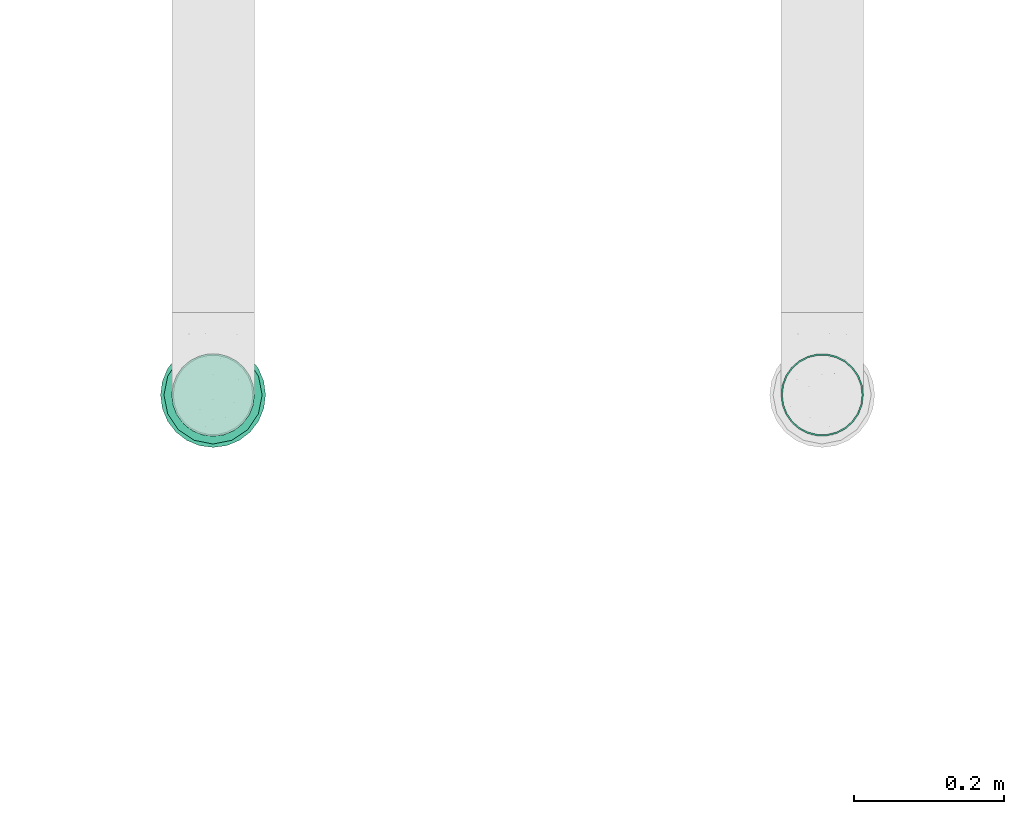
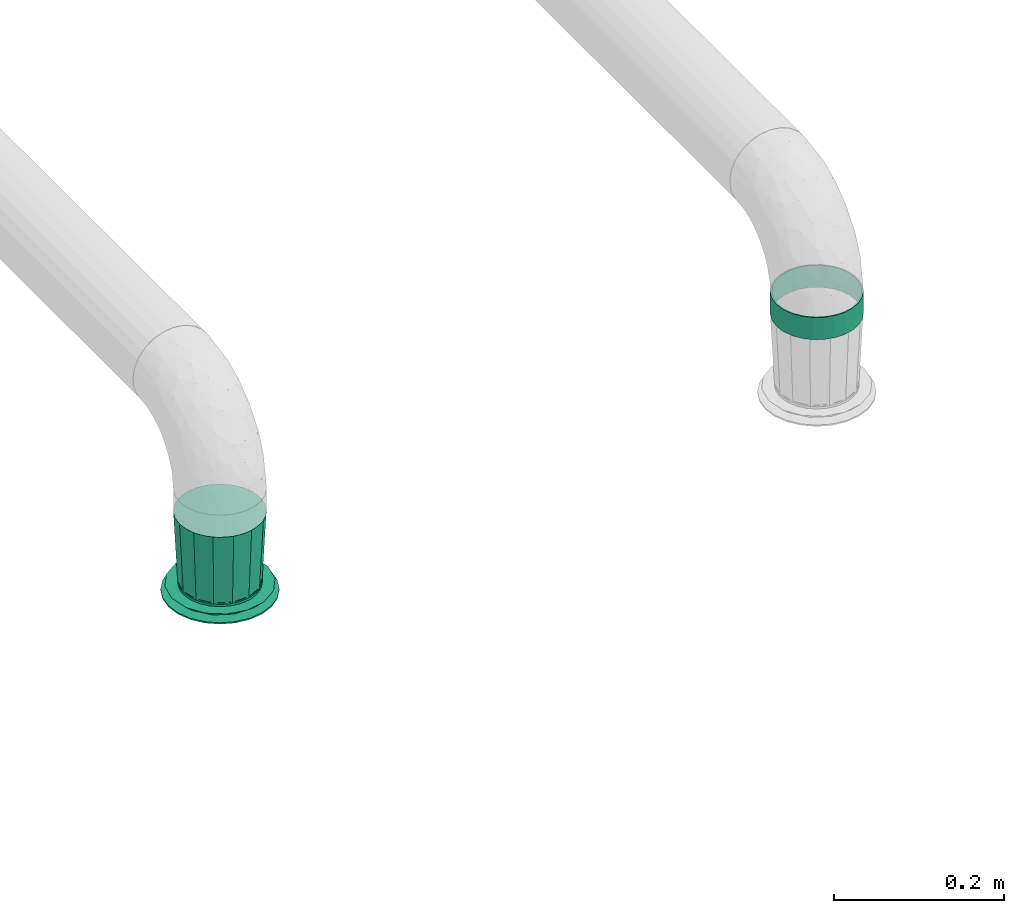
# One storey, part 30 of 103: 1 flow fitting, 1 flow segment, 1 flow terminal.
"""IFC2X3 building model written with IfcOpenShell, lengths in millimetres."""

import ifcopenshell
import ifcopenshell.guid

model = None  # the IFC model being written
_history = None  # IfcOwnerHistory: only IFC2X3 demands one
_inside = {}  # id of a spatial element -> (the spatial element, [elements in it])
_under = {}  # id of a project, library or spatial element -> (it, [spatial elements below it])
_declared = {}  # id of a project -> (the project, [libraries it declares])
_typed = {}  # id of a type object -> (the type object, [elements of that type])
_made_of = {}  # id of a material, layer set ... -> (it, [elements and type objects made of it])


def new_model(schema):
    """Start an empty IFC model of exactly this schema.

    Asked for "IFC4X3", IfcOpenShell would pick the latest addendum, in which some entities
    have other attributes; the version numbers below select the first issue.
    IFC2X3 requires an IfcOwnerHistory on every rooted entity: one is made here for all.
    """
    global model, _history
    if schema == "IFC4X3":
        model = ifcopenshell.file(schema_version=(4, 3, 0, 0))
    else:
        model = ifcopenshell.file(schema=schema)
    _inside.clear()
    _under.clear()
    _declared.clear()
    _typed.clear()
    _made_of.clear()
    _history = None
    if model.schema == "IFC2X3":
        org = make("IfcOrganization", Name="unknown")
        user = make(
            "IfcPersonAndOrganization",
            ThePerson=make("IfcPerson", FamilyName="unknown"),
            TheOrganization=org,
        )
        app = make(
            "IfcApplication",
            ApplicationDeveloper=org,
            Version="unknown",
            ApplicationFullName="unknown",
            ApplicationIdentifier="unknown",
        )
        _history = make(
            "IfcOwnerHistory",
            OwningUser=user,
            OwningApplication=app,
            ChangeAction="ADDED",
            CreationDate=0,
        )
    return model


def make(cls, **values):
    """One entity of the class cls with the attributes given. An attribute that is None is left unset."""
    return model.create_entity(
        cls, **{name: value for name, value in values.items() if value is not None}
    )


def entity(cls, *values):
    """Any entity or typed value of the class cls, its attributes in the order of the schema. None: left unset."""
    e = model.create_entity(cls)
    for i, value in enumerate(values):
        if value is not None:
            e[i] = value
    return e


def rooted(cls, **values):
    """An entity with a GlobalId (a new one), such as an element, a storey or a relation."""
    return make(cls, GlobalId=ifcopenshell.guid.new(), OwnerHistory=_history, **values)


def si_unit(unit_type, name, prefix=None):
    """IfcSIUnit, for example si_unit("LENGTHUNIT", "METRE", prefix="MILLI")."""
    return make("IfcSIUnit", UnitType=unit_type, Prefix=prefix, Name=name)


def converted_unit(unit_type, name, factor, base, dimensions=None, offset=None):
    """IfcConversionBasedUnit, such as the inch: factor (a typed value) times the base unit."""
    return make(
        "IfcConversionBasedUnit"
        if offset is None
        else "IfcConversionBasedUnitWithOffset",
        ConversionOffset=offset,
        Dimensions=None
        if dimensions is None
        else entity("IfcDimensionalExponents", *dimensions),
        UnitType=unit_type,
        Name=name,
        ConversionFactor=make(
            "IfcMeasureWithUnit", ValueComponent=factor, UnitComponent=base
        ),
    )


def derived_unit(unit_type, elements):
    """IfcDerivedUnit: a product of units, each with its exponent."""
    return make(
        "IfcDerivedUnit",
        Elements=[
            make("IfcDerivedUnitElement", Unit=unit, Exponent=power)
            for unit, power in elements
        ],
        UnitType=unit_type,
    )


def assignment(units):
    """IfcUnitAssignment: the units of a project."""
    return None if units is None else make("IfcUnitAssignment", Units=units)


def point(xyz):
    """IfcCartesianPoint."""
    return None if xyz is None else make("IfcCartesianPoint", Coordinates=xyz)


def direction(xyz):
    """IfcDirection."""
    return None if xyz is None else make("IfcDirection", DirectionRatios=xyz)


def frame(location, z_axis=None, x_axis=None):
    """IfcAxis2Placement3D, a coordinate frame: its origin and axes. An axis left out is left unset."""
    return make(
        "IfcAxis2Placement3D",
        Location=point(location),
        Axis=direction(z_axis),
        RefDirection=direction(x_axis),
    )


def frame_2d(location, x_axis=None):
    """IfcAxis2Placement2D, a coordinate frame in the plane: its origin and x axis."""
    return make(
        "IfcAxis2Placement2D", Location=point(location), RefDirection=direction(x_axis)
    )


def origin_with_axes():
    """The frame at (0, 0, 0) with the z axis (0, 0, 1) and the x axis (1, 0, 0) written out."""
    return frame((0.0, 0.0, 0.0), z_axis=(0.0, 0.0, 1.0), x_axis=(1.0, 0.0, 0.0))


def origin_2d_with_axis():
    """The frame at (0, 0) in the plane with the x axis (1, 0) written out."""
    return frame_2d((0.0, 0.0), x_axis=(1.0, 0.0))


def place(relative_to, where):
    """IfcLocalPlacement: puts the frame where relative to a parent placement (None: the world)."""
    return make(
        "IfcLocalPlacement", PlacementRelTo=relative_to, RelativePlacement=where
    )


def context(
    kind, dimensions, precision=None, world=None, true_north=None, identifier=None
):
    """IfcGeometricRepresentationContext, for example the 3D "Model" context."""
    return make(
        "IfcGeometricRepresentationContext",
        ContextIdentifier=identifier,
        ContextType=kind,
        CoordinateSpaceDimension=dimensions,
        Precision=precision,
        WorldCoordinateSystem=world,
        TrueNorth=true_north,
    )


def subcontext(parent, identifier, kind, view, scale=None):
    """IfcGeometricRepresentationSubContext, for example "Body" below "Model"."""
    return make(
        "IfcGeometricRepresentationSubContext",
        ContextIdentifier=identifier,
        ContextType=kind,
        ParentContext=parent,
        TargetScale=scale,
        TargetView=view,
    )


def project(units=None, contexts=None):
    """IfcProject with its units and contexts."""
    return rooted(
        "IfcProject",
        Name="project",
        RepresentationContexts=contexts,
        UnitsInContext=assignment(units),
    )


def spatial(cls, under=None, at=None, **own):
    """A site, building, storey or space (cls), placed at a placement, below another one or the project."""
    s = rooted(cls, ObjectPlacement=at, **own)
    if under is not None:
        _under.setdefault(under.id(), (under, []))[1].append(s)
    return s


def profile(cls, at=None, kind="AREA", **sizes):
    """A parametric profile (cls). Its sizes go by their IFC names, for example OverallWidth=200.0."""
    return make(cls, ProfileType=kind, Position=at, **sizes)


def hollow_circle(**sizes):
    """IfcCircleHollowProfileDef."""
    return profile("IfcCircleHollowProfileDef", **sizes)


def extrude(swept, where, along, depth):
    """IfcExtrudedAreaSolid: the profile swept, set in the frame where, extruded along a direction by depth."""
    return make(
        "IfcExtrudedAreaSolid",
        SweptArea=swept,
        Position=where,
        ExtrudedDirection=direction(along),
        Depth=depth,
    )


def faces_of(points, faces, orient=None, outer=None):
    """IfcFace entities. A face is a list of loops; a loop is a list of indices into points, from 0.

    orient and outer hold one flag for each loop. By default every Orientation is true, the
    first loop of a face is its IfcFaceOuterBound and the others are IfcFaceBound.
    """
    made = []
    for i, loops in enumerate(faces):
        bounds = []
        for j, loop in enumerate(loops):
            is_outer = j == 0 if outer is None else outer[i][j]
            bounds.append(
                make(
                    "IfcFaceOuterBound" if is_outer else "IfcFaceBound",
                    Bound=make("IfcPolyLoop", Polygon=[points[k] for k in loop]),
                    Orientation=True if orient is None else orient[i][j],
                )
            )
        made.append(make("IfcFace", Bounds=bounds))
    return made


def open_shell(faces, orient=None, outer=None):
    """The faces of one IfcOpenShell. surface_model builds it on its shared points."""
    return ("IfcOpenShell", faces, orient, outer)


def surface_model(cls, points, shells):
    """IfcFaceBasedSurfaceModel or IfcShellBasedSurfaceModel (cls): surfaces that need not close."""
    shared = [point(p) for p in points]
    made = [make(c, CfsFaces=faces_of(shared, fs, o, b)) for c, fs, o, b in shells]
    if cls == "IfcFaceBasedSurfaceModel":
        return make(cls, FbsmFaces=made)
    return make(cls, SbsmBoundary=made)


def shape(context_of_items, identifier, shape_type, items):
    """IfcShapeRepresentation: the items that make up one representation, for example the "Body"."""
    return make(
        "IfcShapeRepresentation",
        ContextOfItems=context_of_items,
        RepresentationIdentifier=identifier,
        RepresentationType=shape_type,
        Items=items,
    )


def source(mapping_origin, context_of_items, identifier, shape_type, items):
    """IfcRepresentationMap: a shape defined once, which mapped items show again and again."""
    return make(
        "IfcRepresentationMap",
        MappingOrigin=mapping_origin,
        MappedRepresentation=shape(context_of_items, identifier, shape_type, items),
    )


def transform(
    local_origin,
    x_axis=None,
    y_axis=None,
    z_axis=None,
    scale=None,
    scale2=None,
    scale3=None,
    uniform=True,
):
    """IfcCartesianTransformationOperator3D, or its non-uniform kind. x_axis, y_axis, z_axis: its Axis1, 2, 3."""
    if uniform:
        return make(
            "IfcCartesianTransformationOperator3D",
            Axis1=direction(x_axis),
            Axis2=direction(y_axis),
            LocalOrigin=point(local_origin),
            Scale=scale,
            Axis3=direction(z_axis),
        )
    return make(
        "IfcCartesianTransformationOperator3DnonUniform",
        Axis1=direction(x_axis),
        Axis2=direction(y_axis),
        LocalOrigin=point(local_origin),
        Scale=scale,
        Axis3=direction(z_axis),
        Scale2=scale2,
        Scale3=scale3,
    )


def mapped(mapping_source, mapping_target):
    """IfcMappedItem: shows the shape of a source again, moved by a transform."""
    return make(
        "IfcMappedItem", MappingSource=mapping_source, MappingTarget=mapping_target
    )


def material(Name=None, Category=None):
    """IfcMaterial."""
    return make("IfcMaterial", Name=Name, Category=Category)


def layer(
    of_material, thickness, ventilated=None, Name=None, Category=None, Priority=None
):
    """IfcMaterialLayer: one layer of a wall or slab, of a material (None: an air gap)."""
    return make(
        "IfcMaterialLayer",
        Material=of_material,
        LayerThickness=thickness,
        IsVentilated=ventilated,
        Name=Name,
        Category=Category,
        Priority=Priority,
    )


def layer_set(layers, Name=None):
    """IfcMaterialLayerSet."""
    return make("IfcMaterialLayerSet", MaterialLayers=layers, LayerSetName=Name)


def layer_usage(for_layer_set, set_direction, sense, offset, extent=None):
    """IfcMaterialLayerSetUsage: how a layer set lies in its element."""
    return make(
        "IfcMaterialLayerSetUsage",
        ForLayerSet=for_layer_set,
        LayerSetDirection=set_direction,
        DirectionSense=sense,
        OffsetFromReferenceLine=offset,
        ReferenceExtent=extent,
    )


def made_of(thing, what):
    """Note that an element or type object is made of a material, layer set ...; save() writes the relation."""
    if what is not None:
        _made_of.setdefault(what.id(), (what, []))[1].append(thing)
    return thing


def type_object(cls, material=None, **own):
    """A type object (cls), such as IfcWallType, which elements share."""
    return made_of(rooted(cls, **own), material)


def element(
    cls,
    number,
    at=None,
    inside=None,
    cuts=None,
    type_object=None,
    material=None,
    context=None,
    identifier="Body",
    shape_type=None,
    held_by="IfcProductDefinitionShape",
    body=None,
    shapes=None,
    **own,
):
    """One element of the class cls, such as IfcWall. Its Tag is "e" and its number.

    at: its placement. inside: the storey or other place that contains it. cuts: it is an
    opening in that element (IfcRelVoidsElement). A single representation is given by context,
    identifier, shape_type and body (its items); several are given by shapes. held_by: the class
    of the entity that holds the representations. save() writes the other relations.
    """
    e = rooted(cls, Tag="e%d" % number, ObjectPlacement=at, **own)
    if body is not None:
        shapes = [shape(context, identifier, shape_type, body)]
    if shapes is not None:
        e.Representation = make(held_by, Representations=shapes)
    if inside is not None:
        _inside.setdefault(inside.id(), (inside, []))[1].append(e)
    if cuts is not None:
        rooted(
            "IfcRelVoidsElement", RelatingBuildingElement=cuts, RelatedOpeningElement=e
        )
    if type_object is not None:
        _typed.setdefault(type_object.id(), (type_object, []))[1].append(e)
    return made_of(e, material)


def aggregate(whole, parts):
    """IfcRelAggregates: a whole, such as a stair, and the parts it consists of."""
    return rooted("IfcRelAggregates", RelatingObject=whole, RelatedObjects=parts)


def save(model, path):
    """Write the relations noted so far, then the file.

    IfcRelAggregates (storeys below a building ...), IfcRelContainedInSpatialStructure (elements
    in a storey), IfcRelDefinesByType, IfcRelAssociatesMaterial and IfcRelDeclares: one each for
    every whole, place, type object, material and project.
    """
    for whole, parts in _under.values():
        aggregate(whole, parts)
    for where, things in _inside.values():
        rooted(
            "IfcRelContainedInSpatialStructure",
            RelatedElements=things,
            RelatingStructure=where,
        )
    for kind, things in _typed.values():
        rooted("IfcRelDefinesByType", RelatedObjects=things, RelatingType=kind)
    for what, things in _made_of.values():
        rooted("IfcRelAssociatesMaterial", RelatedObjects=things, RelatingMaterial=what)
    for by, libraries in _declared.values():
        rooted("IfcRelDeclares", RelatingContext=by, RelatedDefinitions=libraries)
    model.write(path)


model = new_model("IFC2X3")

# Units and contexts
model_context = context("Model", 3, precision=1e-05, world=origin_with_axes(), true_north=direction((0.0, 1.0)))
body_context = subcontext(model_context, "Body", "Model", "MODEL_VIEW")
ifc_project = project(units=[si_unit("AREAUNIT", "SQUARE_METRE"), si_unit("VOLUMEUNIT", "CUBIC_METRE", prefix="DECI"), si_unit("TIMEUNIT", "SECOND"), si_unit("THERMODYNAMICTEMPERATUREUNIT", "DEGREE_CELSIUS"), si_unit("PRESSUREUNIT", "PASCAL"), si_unit("MASSUNIT", "GRAM", prefix="KILO"), si_unit("LENGTHUNIT", "METRE", prefix="MILLI"), si_unit("POWERUNIT", "WATT"), si_unit("ELECTRICCURRENTUNIT", "AMPERE"), si_unit("ELECTRICVOLTAGEUNIT", "VOLT"), derived_unit("VOLUMETRICFLOWRATEUNIT", [(si_unit("VOLUMEUNIT", "CUBIC_METRE", prefix="DECI"), 1), (si_unit("TIMEUNIT", "SECOND"), -1)]), derived_unit("LINEARVELOCITYUNIT", [(si_unit("LENGTHUNIT", "METRE"), 1), (si_unit("TIMEUNIT", "SECOND"), -1)]), derived_unit("MASSDENSITYUNIT", [(si_unit("MASSUNIT", "GRAM", prefix="KILO"), 1), (si_unit("VOLUMEUNIT", "CUBIC_METRE"), -1)]), converted_unit("PLANEANGLEUNIT", "DEGREE", entity("IfcRatioMeasure", 0.01745), si_unit("PLANEANGLEUNIT", "RADIAN"), dimensions=[0, 0, 0, 0, 0, 0, 0])], contexts=[model_context])

# Site, building, storey
site_placement = place(None, origin_with_axes())
site = spatial("IfcSite", under=ifc_project, at=site_placement, CompositionType="ELEMENT")
building_placement = place(site_placement, origin_with_axes())
building = spatial("IfcBuilding", under=site, at=building_placement, Name="mc-building", CompositionType="ELEMENT")
storey_placement = place(building_placement, frame((0.0, 0.0, 5900.0), z_axis=(0.0, 0.0, 1.0), x_axis=(1.0, 0.0, 0.0)))
storey = spatial("IfcBuildingStorey", under=building, at=storey_placement, Name="3. Korrus", CompositionType="ELEMENT", Elevation=5900.0)

# Flow terminal
air_terminal_type = type_object("IfcAirTerminalType", Name="100", PredefinedType="NOTDEFINED")
shared_shape_1 = source(origin_with_axes(), body_context, "Body", "SurfaceModel", [
    surface_model("IfcShellBasedSurfaceModel", [(11.2, 18.11733, -67.61481), (11.2, -18.11733, -67.61481), (11.2, 0.0, -70.0), (11.2, 67.61481, -18.11733), (11.2, 35.0, -60.62178), (11.2, 49.49747, -49.49747), (11.2, 60.62178, -35.0), (11.2, -67.61481, 18.11733), (11.2, -49.49747, -49.49747), (11.2, -67.61481, -18.11733), (11.2, -35.0, -60.62178), (11.2, -60.62178, -35.0), (11.2, -70.0, 0.0), (11.2, 18.11733, 67.61481), (11.2, 70.0, 0.0), (11.2, 67.61481, 18.11733), (11.2, 49.49747, 49.49747), (11.2, 60.62178, 35.0), (11.2, 35.0, 60.62178), (11.2, -49.49747, 49.49747), (11.2, -60.62178, 35.0), (11.2, -35.0, 60.62178), (11.2, -18.11733, 67.61481), (11.2, 0.0, 70.0), (9.2, 18.11733, 67.61481), (9.2, -67.61481, 18.11733), (9.2, 0.0, 70.0), (9.2, 49.49747, 49.49747), (9.2, 35.0, 60.62178), (9.2, 60.62178, 35.0), (9.2, 67.61481, 18.11733), (9.2, -35.0, 60.62178), (9.2, -49.49747, 49.49747), (9.2, -18.11733, 67.61481), (9.2, -60.62178, 35.0), (9.2, -67.61481, -18.11733), (9.2, -70.0, 0.0), (9.2, 67.61481, -18.11733), (9.2, 18.11733, -67.61481), (9.2, 49.49747, -49.49747), (9.2, 60.62178, -35.0), (9.2, 35.0, -60.62178), (9.2, -18.11733, -67.61481), (9.2, -49.49747, -49.49747), (9.2, -60.62178, -35.0), (9.2, -35.0, -60.62178), (9.2, 0.0, -70.0), (9.2, 70.0, 0.0), (9.2, 32.75, 0.0), (9.2, -16.375, 28.36233), (9.2, -28.36233, 16.375), (9.2, 16.375, 28.36233), (9.2, 0.0, 32.75), (9.2, 28.36233, 16.375), (9.2, -32.75, 0.0), (9.2, -16.375, -28.36233), (9.2, 16.375, -28.36233), (9.2, 0.0, -32.75), (9.2, 28.36233, -16.375), (9.2, -28.36233, -16.375), (6.2, -21.19625, -15.39997), (6.2, -21.19625, 15.39997), (6.2, 8.09625, 24.91768), (6.2, -8.09625, 24.91768), (6.2, -26.2, 0.0), (6.2, 21.19625, 15.39997), (6.2, -8.09625, -24.91768), (6.2, 21.19625, -15.39997), (6.2, 8.09625, -24.91768), (6.2, 26.2, 0.0), (9.2, 31.06579, -6.28555), (6.2, 23.69812, -7.69999), (6.2, -14.64625, -20.15883), (9.2, -22.36867, -22.36867), (6.2, -23.69812, -7.69999), (9.2, -31.06579, -6.28555), (6.2, 14.64625, -20.15883), (9.2, 8.1875, -30.55617), (6.2, 0.0, -24.91768), (9.2, 22.36867, -22.36867), (9.2, -8.1875, -30.55617), (9.2, -31.06579, 6.28555), (6.2, -23.69812, 7.69999), (6.2, 14.64625, 20.15883), (9.2, 22.36867, 22.36867), (6.2, 23.69812, 7.69999), (9.2, 31.06579, 6.28555), (6.2, -14.64625, 20.15883), (9.2, -8.1875, 30.55617), (6.2, 0.0, 24.91768), (9.2, -22.36867, 22.36867), (9.2, 8.1875, 30.55617), (6.2, -13.11761, 57.472), (6.2, -36.75472, 46.08897), (6.2, -53.11211, 25.57744), (6.2, 36.75472, 46.08897), (6.2, -58.95, 0.0), (6.2, 13.11761, 57.472), (6.2, 53.11211, 25.57744), (6.2, -53.11211, -25.57744), (6.2, -36.75472, -46.08897), (6.2, -13.11761, -57.472), (6.2, 58.95, 0.0), (6.2, 53.11211, -25.57744), (6.2, 13.11761, -57.472), (6.2, 36.75472, -46.08897), (0.0, -60.51411, 25.06576), (0.0, 0.0, 65.5), (0.0, 25.06576, 60.51411), (0.0, 46.3155, 46.3155), (0.0, 60.51411, 25.06576), (0.0, -46.3155, 46.3155), (0.0, -25.06576, 60.51411), (0.0, 0.0, -65.5), (0.0, -65.5, 0.0), (0.0, 65.5, 0.0), (0.0, 60.51411, -25.06576), (0.0, 46.3155, -46.3155), (0.0, 25.06576, -60.51411), (0.0, -46.3155, -46.3155), (0.0, -60.51411, -25.06576), (0.0, -25.06576, -60.51411), (6.2, 56.03105, -12.78872), (0.0, 53.4148, -35.69063), (0.0, 35.69063, -53.4148), (6.2, 24.93616, -51.78048), (0.0, -12.53288, -63.00706), (6.2, 0.0, -57.472), (0.0, -35.69063, -53.4148), (0.0, 63.00706, -12.53288), (6.2, 44.93342, -35.83321), (6.2, -24.93616, -51.78048), (6.2, -44.93342, -35.83321), (0.0, -53.4148, -35.69063), (0.0, 12.53288, -63.00706), (6.2, -56.03105, -12.78872), (0.0, -63.00706, -12.53288), (6.2, -56.03105, 12.78872), (0.0, -53.4148, 35.69063), (0.0, -35.69063, 53.4148), (6.2, -24.93616, 51.78048), (0.0, 12.53288, 63.00706), (6.2, 0.0, 57.472), (0.0, 35.69063, 53.4148), (0.0, -63.00706, 12.53288), (6.2, -44.93342, 35.83321), (6.2, 24.93616, 51.78048), (6.2, 44.93342, 35.83321), (0.0, 53.4148, 35.69063), (0.0, -12.53288, 63.00706), (6.2, 56.03105, 12.78872), (0.0, 63.00706, 12.53288), (-3.1, 12.94095, 48.29629), (-3.1, -35.35534, 35.35534), (-3.1, 0.0, 50.0), (-3.1, 35.35534, 35.35534), (-3.1, 25.0, 43.30127), (-3.1, -43.30127, 25.0), (-3.1, 43.30127, 25.0), (-3.1, -48.29629, -12.94095), (-3.1, -12.94095, 48.29629), (-3.1, -25.0, 43.30127), (-3.1, -50.0, 0.0), (-3.1, -48.29629, 12.94095), (-3.1, 48.29629, 12.94095), (-3.1, 12.94095, -48.29629), (-3.1, 50.0, 0.0), (-3.1, 48.29629, -12.94095), (-3.1, 35.35534, -35.35534), (-3.1, 43.30127, -25.0), (-3.1, 25.0, -43.30127), (-3.1, 0.0, -50.0), (-3.1, -35.35534, -35.35534), (-3.1, -43.30127, -25.0), (-3.1, -25.0, -43.30127), (-3.1, -12.94095, -48.29629), (0.0, 25.0, -43.30127), (0.0, 0.0, -50.0), (0.0, 12.94095, -48.29629), (0.0, 48.29629, -12.94095), (0.0, 35.35534, -35.35534), (0.0, -25.0, -43.30127), (0.0, 43.30127, -25.0), (0.0, -50.0, 0.0), (0.0, -12.94095, -48.29629), (0.0, -35.35534, -35.35534), (0.0, -48.29629, -12.94095), (0.0, -43.30127, -25.0), (0.0, 50.0, 0.0), (0.0, 43.30127, 25.0), (0.0, 12.94095, 48.29629), (0.0, 35.35534, 35.35534), (0.0, 25.0, 43.30127), (0.0, 0.0, 50.0), (0.0, -35.35534, 35.35534), (0.0, -43.30127, 25.0), (0.0, -48.29629, 12.94095), (0.0, -12.94095, 48.29629), (0.0, -25.0, 43.30127), (0.0, 48.29629, 12.94095), (-43.1, 0.0, 45.0), (-43.1, 11.64686, 43.46666), (-43.1, 22.5, 38.97115), (-43.1, -11.64686, 43.46666), (-43.1, 38.97115, 22.5), (-43.1, 43.46666, 11.64686), (-43.1, 31.81981, 31.81981), (-43.1, -22.5, 38.97115), (-43.1, -43.46666, 11.64686), (-43.1, -31.81981, 31.81981), (-43.1, -38.97115, 22.5), (-43.1, -45.0, 0.0), (-43.1, -43.46666, -11.64686), (-43.1, 45.0, 0.0), (-43.1, 43.46666, -11.64686), (-43.1, 38.97115, -22.5), (-43.1, 31.81981, -31.81981), (-43.1, 22.5, -38.97115), (-43.1, 11.64686, -43.46666), (-43.1, -31.81981, -31.81981), (-43.1, -38.97115, -22.5), (-43.1, -22.5, -38.97115), (-43.1, 0.0, -45.0), (-43.1, -11.64686, -43.46666), (-3.1, 22.5, -38.97115), (-3.1, 0.0, -45.0), (-3.1, 11.64686, -43.46666), (-3.1, 31.81981, -31.81981), (-3.1, -22.5, -38.97115), (-3.1, 38.97115, -22.5), (-3.1, 43.46666, -11.64686), (-3.1, 45.0, 0.0), (-3.1, -45.0, 0.0), (-3.1, -11.64686, -43.46666), (-3.1, -31.81981, -31.81981), (-3.1, -43.46666, -11.64686), (-3.1, -38.97115, -22.5), (-3.1, 0.0, 45.0), (-3.1, 43.46666, 11.64686), (-3.1, 38.97115, 22.5), (-3.1, 22.5, 38.97115), (-3.1, 31.81981, 31.81981), (-3.1, 11.64686, 43.46666), (-3.1, -11.64686, 43.46666), (-3.1, -43.46666, 11.64686), (-3.1, -31.81981, 31.81981), (-3.1, -38.97115, 22.5), (-3.1, -22.5, 38.97115)], [open_shell([[[0, 1, 2]], [[3, 0, 4]], [[5, 6, 3]], [[5, 3, 4]], [[7, 1, 0]], [[8, 7, 9]], [[10, 7, 8]], [[8, 9, 11]], [[12, 9, 7]], [[1, 7, 10]], [[7, 0, 3]], [[13, 14, 15]], [[16, 15, 17]], [[16, 18, 13]], [[16, 13, 15]], [[14, 13, 7]], [[7, 19, 20]], [[19, 7, 21]], [[7, 22, 21]], [[22, 7, 23]], [[7, 13, 23]], [[14, 7, 3]], [[24, 25, 26]], [[27, 24, 28]], [[27, 29, 30]], [[27, 30, 24]], [[25, 24, 30]], [[31, 25, 32]], [[25, 31, 33]], [[32, 25, 34]], [[33, 26, 25]], [[25, 35, 36]], [[25, 30, 37]], [[25, 37, 38]], [[39, 37, 40]], [[39, 41, 38]], [[39, 38, 37]], [[38, 42, 25]], [[35, 43, 44]], [[35, 25, 43]], [[45, 43, 25]], [[42, 45, 25]], [[38, 46, 42]], [[37, 30, 47]], [[35, 9, 36]], [[44, 11, 35]], [[10, 43, 45]], [[44, 43, 8]], [[1, 45, 42]], [[35, 11, 9]], [[9, 12, 36]], [[1, 10, 45]], [[8, 43, 10]], [[8, 11, 44]], [[2, 1, 42]], [[42, 46, 2]], [[38, 0, 46]], [[41, 4, 38]], [[6, 39, 40]], [[41, 39, 5]], [[3, 40, 37]], [[41, 5, 4]], [[4, 0, 38]], [[14, 3, 37]], [[6, 40, 3]], [[6, 5, 39]], [[47, 14, 37]], [[46, 0, 2]], [[30, 15, 47]], [[29, 17, 30]], [[18, 27, 28]], [[29, 27, 16]], [[13, 28, 24]], [[30, 17, 15]], [[15, 14, 47]], [[13, 18, 28]], [[16, 27, 18]], [[16, 17, 29]], [[23, 13, 24]], [[24, 26, 23]], [[33, 22, 26]], [[31, 21, 33]], [[20, 32, 34]], [[31, 32, 19]], [[7, 34, 25]], [[31, 19, 21]], [[21, 22, 33]], [[12, 7, 25]], [[20, 34, 7]], [[20, 19, 32]], [[36, 12, 25]], [[26, 22, 23]], [[48, 49, 50]], [[48, 51, 49]], [[49, 51, 52]], [[53, 51, 48]], [[48, 50, 54]], [[54, 55, 48]], [[56, 55, 57]], [[55, 58, 48]], [[58, 55, 56]], [[55, 54, 59]], [[60, 61, 62]], [[62, 61, 63]], [[64, 61, 60]], [[62, 65, 66]], [[67, 68, 65]], [[66, 60, 62]], [[65, 68, 66]], [[69, 67, 65]], [[69, 48, 70]], [[58, 71, 70]], [[72, 73, 60]], [[59, 74, 60]], [[75, 64, 74]], [[56, 68, 76]], [[72, 66, 55]], [[73, 72, 55]], [[68, 77, 78]], [[64, 75, 54]], [[59, 75, 74]], [[70, 71, 69]], [[67, 79, 76]], [[80, 55, 66]], [[68, 56, 77]], [[56, 76, 79]], [[79, 67, 58]], [[71, 58, 67]], [[80, 78, 57]], [[77, 57, 78]], [[66, 78, 80]], [[59, 60, 73]], [[64, 54, 81]], [[50, 82, 81]], [[83, 84, 65]], [[53, 85, 65]], [[86, 69, 85]], [[49, 63, 87]], [[83, 62, 51]], [[84, 83, 51]], [[63, 88, 89]], [[69, 86, 48]], [[53, 86, 85]], [[81, 82, 64]], [[61, 90, 87]], [[91, 51, 62]], [[63, 49, 88]], [[49, 87, 90]], [[90, 61, 50]], [[82, 50, 61]], [[91, 89, 52]], [[88, 52, 89]], [[62, 89, 91]], [[53, 65, 84]], [[92, 93, 94]], [[95, 94, 96]], [[97, 92, 95]], [[95, 92, 94]], [[96, 98, 95]], [[96, 99, 98]], [[99, 100, 101]], [[101, 102, 98]], [[102, 101, 103]], [[104, 105, 103]], [[101, 104, 103]], [[101, 98, 99]], [[106, 107, 108]], [[109, 110, 108]], [[106, 108, 110]], [[111, 112, 106]], [[106, 112, 107]], [[106, 113, 114]], [[106, 110, 113]], [[115, 116, 117]], [[117, 113, 110]], [[113, 117, 118]], [[114, 119, 120]], [[121, 119, 114]], [[121, 114, 113]], [[115, 117, 110]], [[103, 116, 122]], [[123, 116, 103]], [[124, 125, 118]], [[101, 126, 127]], [[100, 119, 128]], [[102, 122, 129]], [[103, 130, 123]], [[102, 129, 115]], [[113, 127, 126]], [[125, 124, 105]], [[130, 105, 117]], [[118, 125, 104]], [[124, 117, 105]], [[131, 100, 128]], [[119, 100, 132]], [[133, 99, 120]], [[134, 118, 104]], [[122, 116, 129]], [[127, 134, 104]], [[131, 121, 101]], [[99, 133, 132]], [[128, 121, 131]], [[130, 117, 123]], [[101, 121, 126]], [[99, 135, 120]], [[96, 136, 135]], [[136, 120, 135]], [[134, 127, 113]], [[133, 119, 132]], [[136, 96, 114]], [[94, 106, 137]], [[138, 106, 94]], [[139, 140, 112]], [[97, 141, 142]], [[95, 109, 143]], [[96, 137, 144]], [[94, 145, 138]], [[96, 144, 114]], [[107, 142, 141]], [[140, 139, 93]], [[145, 93, 111]], [[112, 140, 92]], [[139, 111, 93]], [[146, 95, 143]], [[109, 95, 147]], [[148, 98, 110]], [[149, 112, 92]], [[137, 106, 144]], [[142, 149, 92]], [[146, 108, 97]], [[98, 148, 147]], [[143, 108, 146]], [[145, 111, 138]], [[97, 108, 141]], [[98, 150, 110]], [[102, 151, 150]], [[151, 110, 150]], [[149, 142, 107]], [[148, 109, 147]], [[151, 102, 115]], [[152, 153, 154]], [[155, 152, 156]], [[157, 152, 158]], [[158, 152, 155]], [[158, 159, 157]], [[160, 153, 161]], [[160, 154, 153]], [[157, 162, 163]], [[153, 152, 157]], [[157, 159, 162]], [[158, 164, 159]], [[165, 166, 167]], [[168, 167, 169]], [[170, 165, 167]], [[170, 167, 168]], [[166, 165, 171]], [[159, 172, 173]], [[172, 159, 174]], [[174, 171, 175]], [[159, 164, 174]], [[166, 171, 174]], [[174, 164, 166]], [[176, 177, 178]], [[179, 176, 180]], [[176, 179, 181]], [[179, 180, 182]], [[179, 183, 181]], [[177, 181, 184]], [[177, 176, 181]], [[185, 186, 187]], [[186, 185, 181]], [[181, 183, 186]], [[183, 179, 188]], [[183, 188, 189]], [[190, 189, 191]], [[189, 190, 183]], [[190, 191, 192]], [[193, 194, 190]], [[183, 195, 196]], [[183, 190, 195]], [[194, 197, 198]], [[194, 195, 190]], [[197, 194, 193]], [[189, 188, 199]], [[164, 199, 166]], [[158, 189, 164]], [[192, 155, 156]], [[158, 155, 191]], [[190, 156, 152]], [[164, 189, 199]], [[199, 188, 166]], [[190, 192, 156]], [[191, 155, 192]], [[191, 189, 158]], [[193, 190, 152]], [[152, 154, 193]], [[160, 197, 154]], [[161, 198, 160]], [[195, 153, 157]], [[161, 153, 194]], [[196, 157, 163]], [[161, 194, 198]], [[198, 197, 160]], [[183, 196, 163]], [[195, 157, 196]], [[195, 194, 153]], [[162, 183, 163]], [[154, 197, 193]], [[159, 186, 162]], [[173, 187, 159]], [[181, 172, 174]], [[173, 172, 185]], [[184, 174, 175]], [[159, 187, 186]], [[186, 183, 162]], [[184, 181, 174]], [[185, 172, 181]], [[185, 187, 173]], [[177, 184, 175]], [[175, 171, 177]], [[165, 178, 171]], [[170, 176, 165]], [[182, 168, 169]], [[170, 168, 180]], [[179, 169, 167]], [[170, 180, 176]], [[176, 178, 165]], [[188, 179, 167]], [[182, 169, 179]], [[182, 180, 168]], [[166, 188, 167]], [[171, 178, 177]], [[200, 201, 202]], [[203, 200, 202]], [[204, 205, 202]], [[204, 202, 206]], [[203, 202, 205]], [[207, 208, 209]], [[207, 203, 205]], [[209, 208, 210]], [[211, 208, 212]], [[208, 207, 212]], [[207, 205, 212]], [[213, 214, 215]], [[205, 215, 212]], [[212, 216, 217]], [[216, 212, 215]], [[218, 219, 217]], [[212, 219, 220]], [[212, 217, 219]], [[221, 222, 223]], [[222, 221, 219]], [[218, 222, 219]], [[215, 205, 213]], [[224, 225, 226]], [[227, 228, 224]], [[229, 230, 231]], [[228, 227, 229]], [[229, 232, 228]], [[225, 228, 233]], [[225, 224, 228]], [[234, 235, 236]], [[235, 234, 228]], [[228, 232, 235]], [[232, 229, 231]], [[237, 238, 239]], [[240, 239, 241]], [[240, 242, 237]], [[240, 237, 239]], [[238, 237, 243]], [[244, 245, 246]], [[247, 244, 232]], [[244, 247, 245]], [[232, 238, 247]], [[238, 243, 247]], [[238, 232, 231]], [[205, 238, 213]], [[204, 239, 205]], [[240, 206, 202]], [[204, 206, 241]], [[242, 202, 201]], [[205, 239, 238]], [[238, 231, 213]], [[240, 202, 242]], [[241, 206, 240]], [[241, 239, 204]], [[201, 237, 242]], [[201, 200, 237]], [[243, 203, 207]], [[209, 247, 207]], [[246, 210, 208]], [[209, 210, 245]], [[244, 208, 211]], [[203, 243, 200]], [[207, 247, 243]], [[200, 243, 237]], [[209, 245, 247]], [[210, 246, 245]], [[244, 246, 208]], [[211, 232, 244]], [[212, 235, 211]], [[220, 236, 212]], [[228, 219, 221]], [[220, 219, 234]], [[233, 221, 223]], [[212, 236, 235]], [[235, 232, 211]], [[233, 228, 221]], [[234, 219, 228]], [[234, 236, 220]], [[225, 233, 223]], [[223, 222, 225]], [[226, 218, 217]], [[216, 224, 217]], [[229, 215, 214]], [[216, 215, 227]], [[230, 214, 213]], [[218, 226, 222]], [[217, 224, 226]], [[222, 226, 225]], [[216, 227, 224]], [[215, 229, 227]], [[230, 229, 214]], [[213, 231, 230]]])]),
])
flow_terminal_placement = place(storey_placement, frame((11439.21808, 8183.57591, 2100.0), z_axis=(0.0, 1.0, 0.0), x_axis=(0.0, 0.0, -1.0)))
element("IfcFlowTerminal", 1, at=flow_terminal_placement, inside=storey, type_object=air_terminal_type, Name="100", context=body_context, shape_type="MappedRepresentation", body=[
    mapped(shared_shape_1, transform((0.0, 0.0, 0.0), scale=1.0)),
])

# Flow segment
ifc_material = material(Name="FZ1")
ifc_layer = layer(ifc_material, 0.0)
ifc_layer_set = layer_set([ifc_layer], Name="FZ1")
ifc_layer_usage = layer_usage(ifc_layer_set, "AXIS1", "POSITIVE", 0.0)
duct_segment_type = type_object("IfcDuctSegmentType", PredefinedType="RIGIDSEGMENT")
shared_shape_2 = source(origin_with_axes(), body_context, "Body", "SweptSolid", [
    extrude(hollow_circle(Radius=55.0, WallThickness=2.0, at=origin_2d_with_axis()), frame((0.0, 0.0, 0.0), z_axis=(1.0, 0.0, 0.0), x_axis=(0.0, 1.0, 0.0)), (0.0, 0.0, 1.0), 31.9),
])
flow_segment_placement = place(storey_placement, frame((12251.54332, 8183.57591, 2235.0), z_axis=(0.0, 1.0, 0.0), x_axis=(0.0, 0.0, -1.0)))
element("IfcFlowSegment", 2, at=flow_segment_placement, inside=storey, type_object=duct_segment_type, material=ifc_layer_usage, context=body_context, shape_type="MappedRepresentation", body=[
    mapped(shared_shape_2, transform((0.0, 0.0, 0.0), scale=1.0)),
])

# Flow fitting
duct_fitting_type = type_object("IfcDuctFittingType", PredefinedType="TRANSITION")
shared_shape_3 = source(origin_with_axes(), body_context, "Body", "SurfaceModel", [
    surface_model("IfcShellBasedSurfaceModel", [(0.0, 12.94095, 48.29629), (0.0, -35.35534, 35.35534), (0.0, 0.0, 50.0), (0.0, 35.35534, 35.35534), (0.0, 25.0, 43.30127), (0.0, 43.30127, 25.0), (0.0, 48.29629, 12.94095), (0.0, -12.94095, 48.29629), (0.0, -25.0, 43.30127), (0.0, -48.29629, 12.94095), (0.0, -43.30127, 25.0), (0.0, -25.0, -43.30127), (0.0, -48.29629, -12.94095), (0.0, -50.0, 0.0), (0.0, 48.29629, -12.94095), (0.0, 12.94095, -48.29629), (0.0, 43.30127, -25.0), (0.0, 35.35534, -35.35534), (0.0, 25.0, -43.30127), (0.0, -35.35534, -35.35534), (0.0, -43.30127, -25.0), (0.0, -12.94095, -48.29629), (0.0, 0.0, -50.0), (0.0, 50.0, 0.0), (100.0, -55.0, 0.0), (100.0, -12.23865, 53.62104), (100.0, -34.29194, 43.00073), (100.0, 49.55329, -23.86361), (100.0, 12.23865, 53.62104), (100.0, 34.29194, 43.00073), (100.0, 55.0, 0.0), (100.0, 49.55329, 23.86361), (100.0, -49.55329, 23.86361), (100.0, 12.23865, -53.62104), (100.0, -49.55329, -23.86361), (100.0, -34.29194, -43.00073), (100.0, 34.29194, -43.00073), (100.0, -12.23865, -53.62104), (0.0, 11.12605, 48.7464), (0.0, -11.12605, 48.7464), (0.0, 31.17449, 39.09157), (0.0, -45.04844, -21.69419), (0.0, -45.04844, 21.69419), (0.0, -31.17449, 39.09157), (0.0, 45.04844, 21.69419), (0.0, 45.04844, -21.69419), (0.0, 31.17449, -39.09157), (0.0, -31.17449, -39.09157), (0.0, -11.12605, -48.7464), (0.0, 11.12605, -48.7464), (0.0, -47.52422, -10.84709), (100.0, -41.92261, -33.43217), (0.0, -38.11147, -30.39288), (100.0, 41.92261, -33.43217), (0.0, 38.11147, -30.39288), (0.0, -21.15027, -43.91899), (100.0, -23.2653, -48.31088), (100.0, -52.32388, -11.72483), (100.0, 0.0, -53.62104), (0.0, 0.0, -48.7464), (100.0, 23.2653, -48.31088), (0.0, 21.15027, -43.91899), (100.0, 52.32388, -11.72483), (0.0, 47.52422, -10.84709), (0.0, 47.52422, 10.84709), (100.0, 41.92261, 33.43217), (0.0, 38.11147, 30.39288), (100.0, -41.92261, 33.43217), (0.0, -38.11147, 30.39288), (0.0, 21.15027, 43.91899), (100.0, 23.2653, 48.31088), (100.0, 52.32388, 11.72483), (100.0, 0.0, 53.62104), (0.0, 0.0, 48.7464), (100.0, -23.2653, 48.31088), (0.0, -21.15027, 43.91899), (100.0, -52.32388, 11.72483), (0.0, -47.52422, 10.84709), (100.0, 27.5, -47.63139), (100.0, 0.0, -55.0), (100.0, 14.23505, -53.12592), (100.0, 38.89087, -38.89087), (100.0, -27.5, -47.63139), (100.0, 47.63139, -27.5), (100.0, 53.12592, -14.23505), (100.0, -14.23505, -53.12592), (100.0, -47.63139, -27.5), (100.0, -38.89087, -38.89087), (100.0, -53.12592, -14.23505), (100.0, 53.12592, 14.23505), (100.0, 47.63139, 27.5), (100.0, 27.5, 47.63139), (100.0, 38.89087, 38.89087), (100.0, 14.23505, 53.12592), (100.0, 0.0, 55.0), (100.0, -47.63139, 27.5), (100.0, -53.12592, 14.23505), (100.0, -27.5, 47.63139), (100.0, -38.89087, 38.89087), (100.0, -14.23505, 53.12592), (98.0, 0.0, 55.0), (98.0, 14.23505, 53.12592), (98.0, 27.5, 47.63139), (98.0, 38.89087, 38.89087), (98.0, 47.63139, 27.5), (98.0, -47.63139, 27.5), (98.0, 53.12592, -14.23505), (98.0, -27.5, 47.63139), (98.0, -14.23505, 53.12592), (98.0, -38.89087, 38.89087), (98.0, -55.0, 0.0), (98.0, -53.12592, 14.23505), (98.0, 53.12592, 14.23505), (98.0, 47.63139, -27.5), (98.0, -27.5, -47.63139), (98.0, 0.0, -55.0), (98.0, 38.89087, -38.89087), (98.0, 27.5, -47.63139), (98.0, 14.23505, -53.12592), (98.0, -47.63139, -27.5), (98.0, -38.89087, -38.89087), (98.0, -53.12592, -14.23505), (98.0, -14.23505, -53.12592), (98.0, 55.0, 0.0), (2.0, 12.94095, -48.29629), (2.0, 25.0, -43.30127), (2.0, 35.35534, -35.35534), (2.0, 43.30127, -25.0), (2.0, 48.29629, -12.94095), (2.0, 0.0, -50.0), (2.0, 50.0, 0.0), (2.0, -25.0, -43.30127), (2.0, -12.94095, -48.29629), (2.0, -35.35534, -35.35534), (2.0, -48.29629, -12.94095), (2.0, -43.30127, -25.0), (2.0, -48.29629, 12.94095), (2.0, 48.29629, 12.94095), (2.0, 43.30127, 25.0), (2.0, 35.35534, 35.35534), (2.0, -35.35534, 35.35534), (2.0, 12.94095, 48.29629), (2.0, 25.0, 43.30127), (2.0, 0.0, 50.0), (2.0, -43.30127, 25.0), (2.0, -50.0, 0.0), (2.0, -12.94095, 48.29629), (2.0, -25.0, 43.30127)], [open_shell([[[0, 1, 2]], [[3, 0, 4]], [[3, 5, 6]], [[0, 3, 1]], [[6, 1, 3]], [[7, 1, 8]], [[7, 2, 1]], [[1, 9, 10]], [[9, 1, 11]], [[12, 13, 9]], [[11, 1, 6]], [[6, 14, 11]], [[15, 14, 16]], [[17, 18, 15]], [[17, 15, 16]], [[11, 14, 15]], [[12, 19, 20]], [[19, 12, 11]], [[15, 21, 11]], [[12, 9, 11]], [[22, 21, 15]], [[14, 6, 23]], [[24, 25, 26]], [[25, 27, 28]], [[29, 28, 27]], [[27, 30, 31]], [[31, 29, 27]], [[24, 26, 32]], [[33, 24, 34]], [[33, 34, 35]], [[36, 27, 33]], [[33, 27, 24]], [[35, 37, 33]], [[24, 27, 25]], [[38, 23, 39]], [[40, 23, 38]], [[41, 42, 43]], [[41, 13, 42]], [[23, 43, 39]], [[40, 44, 23]], [[41, 23, 45]], [[41, 45, 46]], [[47, 41, 48]], [[49, 48, 41]], [[41, 46, 49]], [[23, 41, 43]], [[34, 50, 41]], [[47, 51, 52]], [[45, 27, 53]], [[36, 54, 53]], [[55, 48, 56]], [[34, 57, 50]], [[57, 13, 50]], [[13, 57, 24]], [[55, 35, 47]], [[35, 51, 47]], [[51, 41, 52]], [[58, 59, 49]], [[60, 61, 46]], [[37, 59, 58]], [[62, 63, 23]], [[35, 55, 56]], [[23, 30, 62]], [[53, 54, 45]], [[48, 37, 56]], [[33, 49, 61]], [[49, 33, 58]], [[54, 36, 46]], [[63, 27, 45]], [[34, 41, 51]], [[33, 61, 60]], [[48, 59, 37]], [[27, 63, 62]], [[46, 36, 60]], [[31, 64, 44]], [[40, 65, 66]], [[42, 32, 67]], [[26, 68, 67]], [[69, 38, 70]], [[31, 71, 64]], [[71, 23, 64]], [[23, 71, 30]], [[69, 29, 40]], [[29, 65, 40]], [[65, 44, 66]], [[72, 73, 39]], [[74, 75, 43]], [[28, 73, 72]], [[76, 77, 13]], [[29, 69, 70]], [[13, 24, 76]], [[67, 68, 42]], [[38, 28, 70]], [[25, 39, 75]], [[39, 25, 72]], [[68, 26, 43]], [[77, 32, 42]], [[31, 44, 65]], [[25, 75, 74]], [[38, 73, 28]], [[32, 77, 76]], [[43, 26, 74]], [[78, 79, 80]], [[81, 82, 78]], [[82, 83, 84]], [[81, 83, 82]], [[30, 82, 84]], [[79, 82, 85]], [[79, 78, 82]], [[82, 86, 87]], [[82, 30, 86]], [[24, 88, 86]], [[86, 30, 89]], [[90, 24, 89]], [[91, 90, 92]], [[91, 93, 94]], [[90, 91, 24]], [[94, 95, 91]], [[24, 95, 96]], [[24, 91, 95]], [[94, 97, 98]], [[98, 95, 94]], [[97, 94, 99]], [[89, 24, 86]], [[100, 101, 102]], [[100, 102, 103]], [[100, 104, 105]], [[104, 100, 103]], [[106, 105, 104]], [[100, 107, 108]], [[100, 109, 107]], [[105, 110, 111]], [[109, 100, 105]], [[105, 106, 110]], [[106, 104, 112]], [[106, 113, 110]], [[113, 114, 110]], [[115, 116, 117]], [[113, 116, 115]], [[117, 118, 115]], [[119, 114, 120]], [[121, 110, 119]], [[114, 115, 122]], [[119, 110, 114]], [[115, 114, 113]], [[123, 106, 112]], [[121, 88, 110]], [[119, 86, 121]], [[82, 120, 114]], [[119, 120, 87]], [[85, 114, 122]], [[121, 86, 88]], [[88, 24, 110]], [[85, 82, 114]], [[87, 120, 82]], [[87, 86, 119]], [[79, 85, 122]], [[122, 115, 79]], [[118, 80, 115]], [[117, 78, 118]], [[83, 116, 113]], [[117, 116, 81]], [[84, 113, 106]], [[117, 81, 78]], [[78, 80, 118]], [[30, 84, 106]], [[83, 113, 84]], [[83, 81, 116]], [[123, 30, 106]], [[115, 80, 79]], [[112, 89, 123]], [[104, 90, 112]], [[91, 103, 102]], [[104, 103, 92]], [[93, 102, 101]], [[112, 90, 89]], [[89, 30, 123]], [[93, 91, 102]], [[92, 103, 91]], [[92, 90, 104]], [[94, 93, 101]], [[101, 100, 94]], [[108, 99, 100]], [[107, 97, 108]], [[95, 109, 105]], [[107, 109, 98]], [[96, 105, 111]], [[107, 98, 97]], [[97, 99, 108]], [[24, 96, 111]], [[95, 105, 96]], [[95, 98, 109]], [[110, 24, 111]], [[100, 99, 94]], [[124, 125, 126]], [[124, 126, 127]], [[124, 128, 129]], [[128, 124, 127]], [[129, 128, 130]], [[129, 131, 132]], [[129, 130, 131]], [[133, 134, 135]], [[134, 133, 131]], [[131, 136, 134]], [[131, 130, 137]], [[137, 138, 139]], [[140, 137, 139]], [[140, 139, 141]], [[141, 139, 142]], [[140, 141, 143]], [[136, 140, 144]], [[145, 134, 136]], [[140, 146, 147]], [[131, 140, 136]], [[143, 146, 140]], [[131, 137, 140]], [[12, 134, 13]], [[20, 135, 12]], [[131, 19, 11]], [[20, 19, 133]], [[132, 11, 21]], [[12, 135, 134]], [[134, 145, 13]], [[132, 131, 11]], [[133, 19, 131]], [[133, 135, 20]], [[129, 132, 21]], [[21, 22, 129]], [[15, 124, 22]], [[18, 125, 15]], [[127, 17, 16]], [[18, 17, 126]], [[128, 16, 14]], [[18, 126, 125]], [[125, 124, 15]], [[130, 128, 14]], [[127, 16, 128]], [[127, 126, 17]], [[23, 130, 14]], [[22, 124, 129]], [[6, 137, 23]], [[5, 138, 6]], [[142, 3, 4]], [[5, 3, 139]], [[141, 4, 0]], [[6, 138, 137]], [[137, 130, 23]], [[141, 142, 4]], [[139, 3, 142]], [[139, 138, 5]], [[143, 141, 0]], [[0, 2, 143]], [[7, 146, 2]], [[8, 147, 7]], [[144, 1, 10]], [[8, 1, 140]], [[136, 10, 9]], [[8, 140, 147]], [[147, 146, 7]], [[145, 136, 9]], [[144, 10, 136]], [[144, 140, 1]], [[13, 145, 9]], [[2, 146, 143]]])]),
])
flow_fitting_placement = place(storey_placement, frame((11439.21808, 8183.57591, 2103.1), z_axis=(0.0, 1.0, 0.0), x_axis=(0.0, 0.0, 1.0)))
element("IfcFlowFitting", 3, at=flow_fitting_placement, inside=storey, type_object=duct_fitting_type, context=body_context, shape_type="MappedRepresentation", body=[
    mapped(shared_shape_3, transform((0.0, 0.0, 0.0), scale=1.0)),
])

save(model, "model.ifc")
